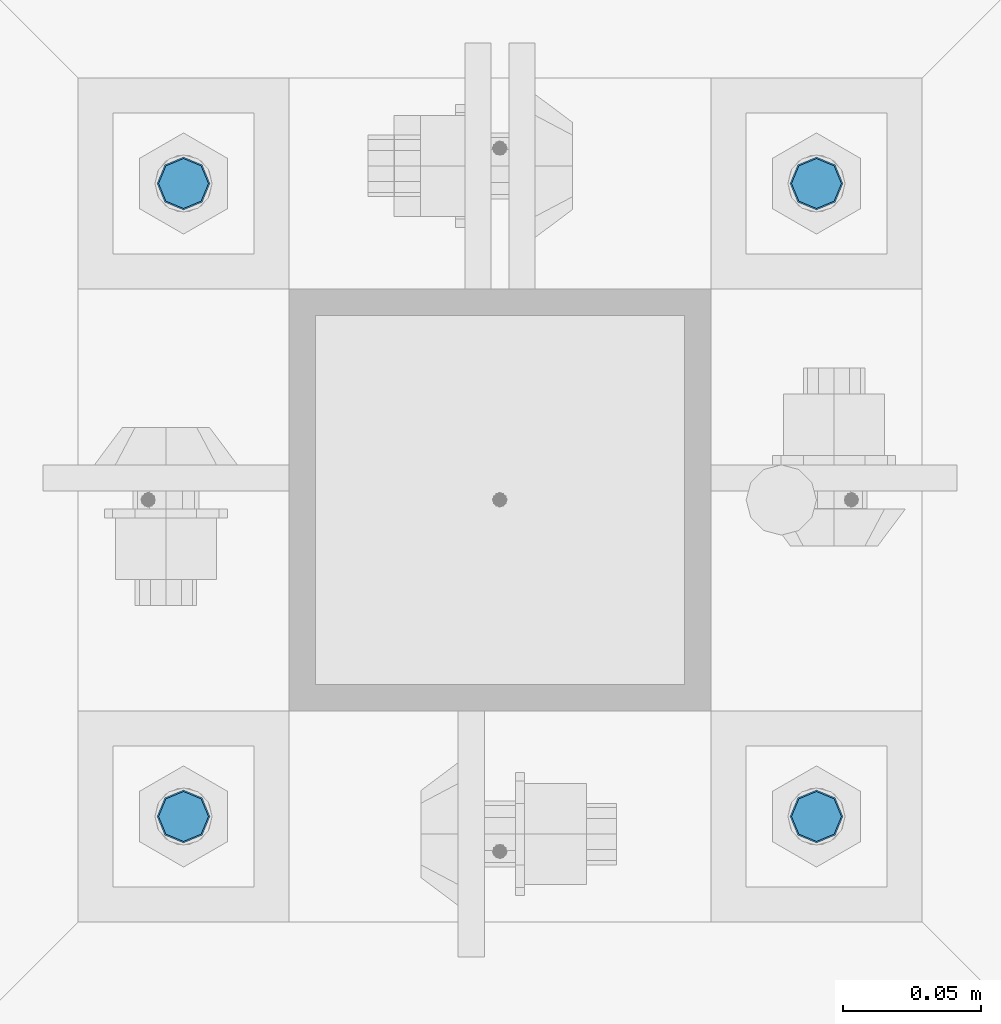
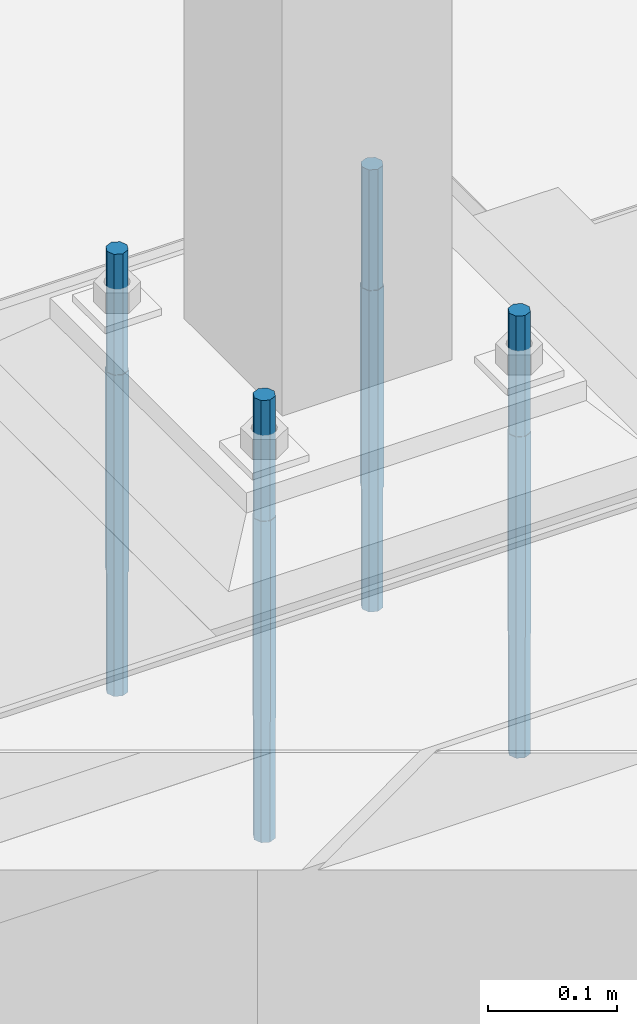
# One storey, part 1476 of 3843: 4 columns, 1 element without a shape of its own.
"""IFC2X3 building model written with IfcOpenShell, lengths in millimetres."""

import ifcopenshell
import ifcopenshell.guid

model = None  # the IFC model being written
_history = None  # IfcOwnerHistory: only IFC2X3 demands one
_inside = {}  # id of a spatial element -> (the spatial element, [elements in it])
_under = {}  # id of a project, library or spatial element -> (it, [spatial elements below it])
_declared = {}  # id of a project -> (the project, [libraries it declares])
_typed = {}  # id of a type object -> (the type object, [elements of that type])
_made_of = {}  # id of a material, layer set ... -> (it, [elements and type objects made of it])


def new_model(schema):
    """Start an empty IFC model of exactly this schema.

    Asked for "IFC4X3", IfcOpenShell would pick the latest addendum, in which some entities
    have other attributes; the version numbers below select the first issue.
    IFC2X3 requires an IfcOwnerHistory on every rooted entity: one is made here for all.
    """
    global model, _history
    if schema == "IFC4X3":
        model = ifcopenshell.file(schema_version=(4, 3, 0, 0))
    else:
        model = ifcopenshell.file(schema=schema)
    _inside.clear()
    _under.clear()
    _declared.clear()
    _typed.clear()
    _made_of.clear()
    _history = None
    if model.schema == "IFC2X3":
        org = make("IfcOrganization", Name="unknown")
        user = make(
            "IfcPersonAndOrganization",
            ThePerson=make("IfcPerson", FamilyName="unknown"),
            TheOrganization=org,
        )
        app = make(
            "IfcApplication",
            ApplicationDeveloper=org,
            Version="unknown",
            ApplicationFullName="unknown",
            ApplicationIdentifier="unknown",
        )
        _history = make(
            "IfcOwnerHistory",
            OwningUser=user,
            OwningApplication=app,
            ChangeAction="ADDED",
            CreationDate=0,
        )
    return model


def make(cls, **values):
    """One entity of the class cls with the attributes given. An attribute that is None is left unset."""
    return model.create_entity(
        cls, **{name: value for name, value in values.items() if value is not None}
    )


def rooted(cls, **values):
    """An entity with a GlobalId (a new one), such as an element, a storey or a relation."""
    return make(cls, GlobalId=ifcopenshell.guid.new(), OwnerHistory=_history, **values)


def si_unit(unit_type, name, prefix=None):
    """IfcSIUnit, for example si_unit("LENGTHUNIT", "METRE", prefix="MILLI")."""
    return make("IfcSIUnit", UnitType=unit_type, Prefix=prefix, Name=name)


def assignment(units):
    """IfcUnitAssignment: the units of a project."""
    return None if units is None else make("IfcUnitAssignment", Units=units)


def point(xyz):
    """IfcCartesianPoint."""
    return None if xyz is None else make("IfcCartesianPoint", Coordinates=xyz)


def direction(xyz):
    """IfcDirection."""
    return None if xyz is None else make("IfcDirection", DirectionRatios=xyz)


def frame(location, z_axis=None, x_axis=None):
    """IfcAxis2Placement3D, a coordinate frame: its origin and axes. An axis left out is left unset."""
    return make(
        "IfcAxis2Placement3D",
        Location=point(location),
        Axis=direction(z_axis),
        RefDirection=direction(x_axis),
    )


def origin_with_axes():
    """The frame at (0, 0, 0) with the z axis (0, 0, 1) and the x axis (1, 0, 0) written out."""
    return frame((0.0, 0.0, 0.0), z_axis=(0.0, 0.0, 1.0), x_axis=(1.0, 0.0, 0.0))


def place(relative_to, where):
    """IfcLocalPlacement: puts the frame where relative to a parent placement (None: the world)."""
    return make(
        "IfcLocalPlacement", PlacementRelTo=relative_to, RelativePlacement=where
    )


def context(
    kind, dimensions, precision=None, world=None, true_north=None, identifier=None
):
    """IfcGeometricRepresentationContext, for example the 3D "Model" context."""
    return make(
        "IfcGeometricRepresentationContext",
        ContextIdentifier=identifier,
        ContextType=kind,
        CoordinateSpaceDimension=dimensions,
        Precision=precision,
        WorldCoordinateSystem=world,
        TrueNorth=true_north,
    )


def subcontext(parent, identifier, kind, view, scale=None):
    """IfcGeometricRepresentationSubContext, for example "Body" below "Model"."""
    return make(
        "IfcGeometricRepresentationSubContext",
        ContextIdentifier=identifier,
        ContextType=kind,
        ParentContext=parent,
        TargetScale=scale,
        TargetView=view,
    )


def project(units=None, contexts=None):
    """IfcProject with its units and contexts."""
    return rooted(
        "IfcProject",
        Name="project",
        RepresentationContexts=contexts,
        UnitsInContext=assignment(units),
    )


def spatial(cls, under=None, at=None, **own):
    """A site, building, storey or space (cls), placed at a placement, below another one or the project."""
    s = rooted(cls, ObjectPlacement=at, **own)
    if under is not None:
        _under.setdefault(under.id(), (under, []))[1].append(s)
    return s


def faces_of(points, faces, orient=None, outer=None):
    """IfcFace entities. A face is a list of loops; a loop is a list of indices into points, from 0.

    orient and outer hold one flag for each loop. By default every Orientation is true, the
    first loop of a face is its IfcFaceOuterBound and the others are IfcFaceBound.
    """
    made = []
    for i, loops in enumerate(faces):
        bounds = []
        for j, loop in enumerate(loops):
            is_outer = j == 0 if outer is None else outer[i][j]
            bounds.append(
                make(
                    "IfcFaceOuterBound" if is_outer else "IfcFaceBound",
                    Bound=make("IfcPolyLoop", Polygon=[points[k] for k in loop]),
                    Orientation=True if orient is None else orient[i][j],
                )
            )
        made.append(make("IfcFace", Bounds=bounds))
    return made


def faceted_brep(points, faces, orient=None, outer=None, voids=None):
    """IfcFacetedBrep: a solid bounded by flat faces; with voids (closed shells), ...WithVoids."""
    shared = [point(p) for p in points]
    hull = make("IfcClosedShell", CfsFaces=faces_of(shared, faces, orient, outer))
    if voids is None:
        return make("IfcFacetedBrep", Outer=hull)
    return make(
        "IfcFacetedBrepWithVoids",
        Outer=hull,
        Voids=[
            make(cls, CfsFaces=faces_of(shared, fs, o, b)) for cls, fs, o, b in voids
        ],
    )


def shape(context_of_items, identifier, shape_type, items):
    """IfcShapeRepresentation: the items that make up one representation, for example the "Body"."""
    return make(
        "IfcShapeRepresentation",
        ContextOfItems=context_of_items,
        RepresentationIdentifier=identifier,
        RepresentationType=shape_type,
        Items=items,
    )


def material(Name=None, Category=None):
    """IfcMaterial."""
    return make("IfcMaterial", Name=Name, Category=Category)


def made_of(thing, what):
    """Note that an element or type object is made of a material, layer set ...; save() writes the relation."""
    if what is not None:
        _made_of.setdefault(what.id(), (what, []))[1].append(thing)
    return thing


def type_object(cls, material=None, **own):
    """A type object (cls), such as IfcWallType, which elements share."""
    return made_of(rooted(cls, **own), material)


def element(
    cls,
    number,
    at=None,
    inside=None,
    cuts=None,
    type_object=None,
    material=None,
    context=None,
    identifier="Body",
    shape_type=None,
    held_by="IfcProductDefinitionShape",
    body=None,
    shapes=None,
    **own,
):
    """One element of the class cls, such as IfcWall. Its Tag is "e" and its number.

    at: its placement. inside: the storey or other place that contains it. cuts: it is an
    opening in that element (IfcRelVoidsElement). A single representation is given by context,
    identifier, shape_type and body (its items); several are given by shapes. held_by: the class
    of the entity that holds the representations. save() writes the other relations.
    """
    e = rooted(cls, Tag="e%d" % number, ObjectPlacement=at, **own)
    if body is not None:
        shapes = [shape(context, identifier, shape_type, body)]
    if shapes is not None:
        e.Representation = make(held_by, Representations=shapes)
    if inside is not None:
        _inside.setdefault(inside.id(), (inside, []))[1].append(e)
    if cuts is not None:
        rooted(
            "IfcRelVoidsElement", RelatingBuildingElement=cuts, RelatedOpeningElement=e
        )
    if type_object is not None:
        _typed.setdefault(type_object.id(), (type_object, []))[1].append(e)
    return made_of(e, material)


def aggregate(whole, parts):
    """IfcRelAggregates: a whole, such as a stair, and the parts it consists of."""
    return rooted("IfcRelAggregates", RelatingObject=whole, RelatedObjects=parts)


def save(model, path):
    """Write the relations noted so far, then the file.

    IfcRelAggregates (storeys below a building ...), IfcRelContainedInSpatialStructure (elements
    in a storey), IfcRelDefinesByType, IfcRelAssociatesMaterial and IfcRelDeclares: one each for
    every whole, place, type object, material and project.
    """
    for whole, parts in _under.values():
        aggregate(whole, parts)
    for where, things in _inside.values():
        rooted(
            "IfcRelContainedInSpatialStructure",
            RelatedElements=things,
            RelatingStructure=where,
        )
    for kind, things in _typed.values():
        rooted("IfcRelDefinesByType", RelatedObjects=things, RelatingType=kind)
    for what, things in _made_of.values():
        rooted("IfcRelAssociatesMaterial", RelatedObjects=things, RelatingMaterial=what)
    for by, libraries in _declared.values():
        rooted("IfcRelDeclares", RelatingContext=by, RelatedDefinitions=libraries)
    model.write(path)


model = new_model("IFC2X3")

# Units and contexts
model_context = context("Model", 3, precision=1e-05, world=origin_with_axes())
body_context = subcontext(model_context, "Body", "Model", "MODEL_VIEW")
ifc_project = project(units=[si_unit("LENGTHUNIT", "METRE", prefix="MILLI"), si_unit("AREAUNIT", "SQUARE_METRE"), si_unit("VOLUMEUNIT", "CUBIC_METRE"), si_unit("MASSUNIT", "GRAM", prefix="KILO"), si_unit("TIMEUNIT", "SECOND"), si_unit("PLANEANGLEUNIT", "RADIAN"), si_unit("SOLIDANGLEUNIT", "STERADIAN"), si_unit("THERMODYNAMICTEMPERATUREUNIT", "DEGREE_CELSIUS"), si_unit("LUMINOUSINTENSITYUNIT", "LUMEN")], contexts=[model_context])

# Site, building, storey
site_placement = place(None, origin_with_axes())
site = spatial("IfcSite", under=ifc_project, at=site_placement, CompositionType="ELEMENT")
building_placement = place(site_placement, origin_with_axes())
building = spatial("IfcBuilding", under=site, at=building_placement, Name="Undefined", CompositionType="ELEMENT")
storey_placement = place(building_placement, origin_with_axes())
storey = spatial("IfcBuildingStorey", under=building, at=storey_placement, Name="Undefined", CompositionType="ELEMENT", Elevation=0.0)

# Assembly, columns
assembly_placement = place(storey_placement, origin_with_axes())
assembly = element("IfcElementAssembly", 1, at=assembly_placement, inside=storey, Name="TEMPLATE", AssemblyPlace="NOTDEFINED", PredefinedType="RIGID_FRAME")
ifc_material = material(Name="Undefined/F1554-GR.55")
column_type = type_object("IfcColumnType", PredefinedType="NOTDEFINED")
column_1_placement = place(assembly_placement, frame((49110.9, 20193.0, 30480.0), z_axis=(1.0, 0.0, 0.0), x_axis=(0.0, 0.0, -1.0)))
column_1 = element("IfcColumn", 2, at=column_1_placement, type_object=column_type, material=ifc_material, Name="ANCHOR_ROD", context=body_context, shape_type="Brep", body=[
    faceted_brep([(-114.300000000003, -6.36396103068546, 6.36396103067818), (-114.300000000003, 0.0, 9.0), (-114.300000000003, 6.36396103068546, 6.36396103067818), (-114.300000000003, 9.0, 0.0), (-114.300000000003, 6.36396103068546, -6.36396103067818), (-114.300000000003, 0.0, -9.0), (-114.300000000003, -6.36396103068546, -6.36396103067818), (-114.300000000003, -9.0, 0.0), (0.0, 6.36396103068546, -6.36396103067818), (0.0, 0.0, -9.0), (0.0, -6.36396103068546, -6.36396103067818), (0.0, -9.0, 0.0), (0.0, -6.36396103068546, 6.36396103067818), (0.0, 0.0, 9.0), (0.0, 6.36396103068546, 6.36396103067818), (0.0, 9.0, 0.0), (0.0, -6.73519209080405, 6.73519209079677), (-9.87109982941227e-13, 2.91322521661641e-12, 9.52499961853027), (0.0, 6.73519209080405, 6.73519209079677), (0.0, 9.52500000000146, 0.0), (0.0, 6.73519209080405, -6.73519209079677), (2.95075507493764e-12, 2.91322521661641e-12, -9.52499961853027), (0.0, -6.73519209080405, -6.73519209079677), (0.0, -9.52500000000146, 0.0), (190.5, -9.52499999999418, 0.0), (190.5, -6.73519209079677, 6.73519209080405), (190.5, 0.0, 9.52500000000146), (190.5, 6.73519209079677, 6.73519209080405), (190.5, 9.52499999999418, 0.0), (190.5, 6.73519209079677, -6.73519209080405), (190.5, 0.0, -9.52500000000146), (190.5, -6.73519209079677, -6.73519209080405), (190.5, -6.36396103068546, 6.36396103067818), (190.5, 0.0, 9.0), (190.5, 6.36396103068546, 6.36396103067818), (190.5, 9.0, 0.0), (190.5, 6.36396103068546, -6.36396103067818), (190.5, 0.0, -9.0), (190.5, -6.36396103068546, -6.36396103067818), (190.5, -9.0, 0.0), (304.799999999999, 0.0, -9.0), (304.799999999999, 6.36396103068546, -6.36396103067818), (304.799999999999, 9.0, 0.0), (304.799999999999, 6.36396103068546, 6.36396103067818), (304.799999999999, 0.0, 9.0), (304.799999999999, -6.36396103068546, 6.36396103067818), (304.799999999999, -9.0, 0.0), (304.799999999999, -6.36396103068546, -6.36396103067818)], [[[0, 1, 2, 3, 4, 5, 6, 7]], [[5, 4, 8, 9]], [[6, 5, 9, 10]], [[7, 6, 10, 11]], [[0, 7, 11, 12]], [[1, 0, 12, 13]], [[2, 1, 13, 14]], [[3, 2, 14, 15]], [[4, 3, 15, 8]], [[16, 17, 18, 19, 20, 21, 22, 23], [14, 13, 12, 11, 10, 9, 8, 15]], [[16, 23, 24, 25]], [[17, 16, 25, 26]], [[18, 17, 26, 27]], [[19, 18, 27, 28]], [[20, 19, 28, 29]], [[21, 20, 29, 30]], [[22, 21, 30, 31]], [[23, 22, 31, 24]], [[30, 29, 28, 27, 26, 25, 24, 31], [32, 33, 34, 35, 36, 37, 38, 39]], [[40, 41, 42, 43, 44, 45, 46, 47]], [[45, 44, 33, 32]], [[46, 45, 32, 39]], [[47, 46, 39, 38]], [[40, 47, 38, 37]], [[41, 40, 37, 36]], [[42, 41, 36, 35]], [[43, 42, 35, 34]], [[44, 43, 34, 33]]]),
])
column_2_placement = place(assembly_placement, frame((49110.9, 20421.6, 30480.0), z_axis=(-1.0, 0.0, 0.0), x_axis=(0.0, 0.0, -1.0)))
column_2 = element("IfcColumn", 3, at=column_2_placement, type_object=column_type, material=ifc_material, Name="ANCHOR_ROD", context=body_context, shape_type="Brep", body=[
    faceted_brep([(-114.300000000003, -6.36396103068546, 6.36396103067818), (-114.300000000003, 0.0, 9.0), (-114.300000000003, 6.36396103068546, 6.36396103067818), (-114.300000000003, 9.0, 0.0), (-114.300000000003, 6.36396103068546, -6.36396103067818), (-114.300000000003, 0.0, -9.0), (-114.300000000003, -6.36396103068546, -6.36396103067818), (-114.300000000003, -9.0, 0.0), (0.0, 6.36396103068546, -6.36396103067818), (0.0, 0.0, -9.0), (0.0, -6.36396103068546, -6.36396103067818), (0.0, -9.0, 0.0), (0.0, -6.36396103068546, 6.36396103067818), (0.0, 0.0, 9.0), (0.0, 6.36396103068546, 6.36396103067818), (0.0, 9.0, 0.0), (0.0, -6.73519209080405, 6.73519209079677), (-9.87109982941227e-13, 2.91322521661641e-12, 9.52499961853027), (0.0, 6.73519209080405, 6.73519209079677), (0.0, 9.52500000000146, 0.0), (0.0, 6.73519209080405, -6.73519209079677), (2.95075507493764e-12, 2.91322521661641e-12, -9.52499961853027), (0.0, -6.73519209080405, -6.73519209079677), (0.0, -9.52500000000146, 0.0), (190.5, -9.52499999999418, 0.0), (190.5, -6.73519209079677, 6.73519209080405), (190.5, 0.0, 9.52500000000146), (190.5, 6.73519209079677, 6.73519209080405), (190.5, 9.52499999999418, 0.0), (190.5, 6.73519209079677, -6.73519209080405), (190.5, 0.0, -9.52500000000146), (190.5, -6.73519209079677, -6.73519209080405), (190.5, -6.36396103068546, 6.36396103067818), (190.5, 0.0, 9.0), (190.5, 6.36396103068546, 6.36396103067818), (190.5, 9.0, 0.0), (190.5, 6.36396103068546, -6.36396103067818), (190.5, 0.0, -9.0), (190.5, -6.36396103068546, -6.36396103067818), (190.5, -9.0, 0.0), (304.799999999999, 0.0, -9.0), (304.799999999999, 6.36396103068546, -6.36396103067818), (304.799999999999, 9.0, 0.0), (304.799999999999, 6.36396103068546, 6.36396103067818), (304.799999999999, 0.0, 9.0), (304.799999999999, -6.36396103068546, 6.36396103067818), (304.799999999999, -9.0, 0.0), (304.799999999999, -6.36396103068546, -6.36396103067818)], [[[0, 1, 2, 3, 4, 5, 6, 7]], [[5, 4, 8, 9]], [[6, 5, 9, 10]], [[7, 6, 10, 11]], [[0, 7, 11, 12]], [[1, 0, 12, 13]], [[2, 1, 13, 14]], [[3, 2, 14, 15]], [[4, 3, 15, 8]], [[16, 17, 18, 19, 20, 21, 22, 23], [14, 13, 12, 11, 10, 9, 8, 15]], [[16, 23, 24, 25]], [[17, 16, 25, 26]], [[18, 17, 26, 27]], [[19, 18, 27, 28]], [[20, 19, 28, 29]], [[21, 20, 29, 30]], [[22, 21, 30, 31]], [[23, 22, 31, 24]], [[30, 29, 28, 27, 26, 25, 24, 31], [32, 33, 34, 35, 36, 37, 38, 39]], [[40, 41, 42, 43, 44, 45, 46, 47]], [[45, 44, 33, 32]], [[46, 45, 32, 39]], [[47, 46, 39, 38]], [[40, 47, 38, 37]], [[41, 40, 37, 36]], [[42, 41, 36, 35]], [[43, 42, 35, 34]], [[44, 43, 34, 33]]]),
])
column_3_placement = place(assembly_placement, frame((48882.3, 20193.0, 30480.0), z_axis=(1.0, 0.0, 0.0), x_axis=(0.0, 0.0, -1.0)))
column_3 = element("IfcColumn", 4, at=column_3_placement, type_object=column_type, material=ifc_material, Name="ANCHOR_ROD", context=body_context, shape_type="Brep", body=[
    faceted_brep([(-114.300000000003, -6.36396103068546, 6.36396103067818), (-114.300000000003, 0.0, 9.0), (-114.300000000003, 6.36396103068546, 6.36396103067818), (-114.300000000003, 9.0, 0.0), (-114.300000000003, 6.36396103068546, -6.36396103067818), (-114.300000000003, 0.0, -9.0), (-114.300000000003, -6.36396103068546, -6.36396103067818), (-114.300000000003, -9.0, 0.0), (0.0, 6.36396103068546, -6.36396103067818), (0.0, 0.0, -9.0), (0.0, -6.36396103068546, -6.36396103067818), (0.0, -9.0, 0.0), (0.0, -6.36396103068546, 6.36396103067818), (0.0, 0.0, 9.0), (0.0, 6.36396103068546, 6.36396103067818), (0.0, 9.0, 0.0), (0.0, -6.73519209080405, 6.73519209079677), (-9.87109982941227e-13, 2.91322521661641e-12, 9.52499961853027), (0.0, 6.73519209080405, 6.73519209079677), (0.0, 9.52500000000146, 0.0), (0.0, 6.73519209080405, -6.73519209079677), (2.95075507493764e-12, 2.91322521661641e-12, -9.52499961853027), (0.0, -6.73519209080405, -6.73519209079677), (0.0, -9.52500000000146, 0.0), (190.5, -9.52499999999418, 0.0), (190.5, -6.73519209079677, 6.73519209080405), (190.5, 0.0, 9.52500000000146), (190.5, 6.73519209079677, 6.73519209080405), (190.5, 9.52499999999418, 0.0), (190.5, 6.73519209079677, -6.73519209080405), (190.5, 0.0, -9.52500000000146), (190.5, -6.73519209079677, -6.73519209080405), (190.5, -6.36396103068546, 6.36396103067818), (190.5, 0.0, 9.0), (190.5, 6.36396103068546, 6.36396103067818), (190.5, 9.0, 0.0), (190.5, 6.36396103068546, -6.36396103067818), (190.5, 0.0, -9.0), (190.5, -6.36396103068546, -6.36396103067818), (190.5, -9.0, 0.0), (304.799999999999, 0.0, -9.0), (304.799999999999, 6.36396103068546, -6.36396103067818), (304.799999999999, 9.0, 0.0), (304.799999999999, 6.36396103068546, 6.36396103067818), (304.799999999999, 0.0, 9.0), (304.799999999999, -6.36396103068546, 6.36396103067818), (304.799999999999, -9.0, 0.0), (304.799999999999, -6.36396103068546, -6.36396103067818)], [[[0, 1, 2, 3, 4, 5, 6, 7]], [[5, 4, 8, 9]], [[6, 5, 9, 10]], [[7, 6, 10, 11]], [[0, 7, 11, 12]], [[1, 0, 12, 13]], [[2, 1, 13, 14]], [[3, 2, 14, 15]], [[4, 3, 15, 8]], [[16, 17, 18, 19, 20, 21, 22, 23], [14, 13, 12, 11, 10, 9, 8, 15]], [[16, 23, 24, 25]], [[17, 16, 25, 26]], [[18, 17, 26, 27]], [[19, 18, 27, 28]], [[20, 19, 28, 29]], [[21, 20, 29, 30]], [[22, 21, 30, 31]], [[23, 22, 31, 24]], [[30, 29, 28, 27, 26, 25, 24, 31], [32, 33, 34, 35, 36, 37, 38, 39]], [[40, 41, 42, 43, 44, 45, 46, 47]], [[45, 44, 33, 32]], [[46, 45, 32, 39]], [[47, 46, 39, 38]], [[40, 47, 38, 37]], [[41, 40, 37, 36]], [[42, 41, 36, 35]], [[43, 42, 35, 34]], [[44, 43, 34, 33]]]),
])
column_4_placement = place(assembly_placement, frame((48882.3, 20421.6, 30480.0), z_axis=(-1.0, 0.0, 0.0), x_axis=(0.0, 0.0, -1.0)))
column_4 = element("IfcColumn", 5, at=column_4_placement, type_object=column_type, material=ifc_material, Name="ANCHOR_ROD", context=body_context, shape_type="Brep", body=[
    faceted_brep([(-114.300000000003, -6.36396103068546, 6.36396103067818), (-114.300000000003, 0.0, 9.0), (-114.300000000003, 6.36396103068546, 6.36396103067818), (-114.300000000003, 9.0, 0.0), (-114.300000000003, 6.36396103068546, -6.36396103067818), (-114.300000000003, 0.0, -9.0), (-114.300000000003, -6.36396103068546, -6.36396103067818), (-114.300000000003, -9.0, 0.0), (0.0, 6.36396103068546, -6.36396103067818), (0.0, 0.0, -9.0), (0.0, -6.36396103068546, -6.36396103067818), (0.0, -9.0, 0.0), (0.0, -6.36396103068546, 6.36396103067818), (0.0, 0.0, 9.0), (0.0, 6.36396103068546, 6.36396103067818), (0.0, 9.0, 0.0), (0.0, -6.73519209080405, 6.73519209079677), (-9.87109982941227e-13, 2.91322521661641e-12, 9.52499961853027), (0.0, 6.73519209080405, 6.73519209079677), (0.0, 9.52500000000146, 0.0), (0.0, 6.73519209080405, -6.73519209079677), (2.95075507493764e-12, 2.91322521661641e-12, -9.52499961853027), (0.0, -6.73519209080405, -6.73519209079677), (0.0, -9.52500000000146, 0.0), (190.5, -9.52499999999418, 0.0), (190.5, -6.73519209079677, 6.73519209080405), (190.5, 0.0, 9.52500000000146), (190.5, 6.73519209079677, 6.73519209080405), (190.5, 9.52499999999418, 0.0), (190.5, 6.73519209079677, -6.73519209080405), (190.5, 0.0, -9.52500000000146), (190.5, -6.73519209079677, -6.73519209080405), (190.5, -6.36396103068546, 6.36396103067818), (190.5, 0.0, 9.0), (190.5, 6.36396103068546, 6.36396103067818), (190.5, 9.0, 0.0), (190.5, 6.36396103068546, -6.36396103067818), (190.5, 0.0, -9.0), (190.5, -6.36396103068546, -6.36396103067818), (190.5, -9.0, 0.0), (304.799999999999, 0.0, -9.0), (304.799999999999, 6.36396103068546, -6.36396103067818), (304.799999999999, 9.0, 0.0), (304.799999999999, 6.36396103068546, 6.36396103067818), (304.799999999999, 0.0, 9.0), (304.799999999999, -6.36396103068546, 6.36396103067818), (304.799999999999, -9.0, 0.0), (304.799999999999, -6.36396103068546, -6.36396103067818)], [[[0, 1, 2, 3, 4, 5, 6, 7]], [[5, 4, 8, 9]], [[6, 5, 9, 10]], [[7, 6, 10, 11]], [[0, 7, 11, 12]], [[1, 0, 12, 13]], [[2, 1, 13, 14]], [[3, 2, 14, 15]], [[4, 3, 15, 8]], [[16, 17, 18, 19, 20, 21, 22, 23], [14, 13, 12, 11, 10, 9, 8, 15]], [[16, 23, 24, 25]], [[17, 16, 25, 26]], [[18, 17, 26, 27]], [[19, 18, 27, 28]], [[20, 19, 28, 29]], [[21, 20, 29, 30]], [[22, 21, 30, 31]], [[23, 22, 31, 24]], [[30, 29, 28, 27, 26, 25, 24, 31], [32, 33, 34, 35, 36, 37, 38, 39]], [[40, 41, 42, 43, 44, 45, 46, 47]], [[45, 44, 33, 32]], [[46, 45, 32, 39]], [[47, 46, 39, 38]], [[40, 47, 38, 37]], [[41, 40, 37, 36]], [[42, 41, 36, 35]], [[43, 42, 35, 34]], [[44, 43, 34, 33]]]),
])
aggregate(assembly, [column_1, column_2, column_3, column_4])

save(model, "model.ifc")
